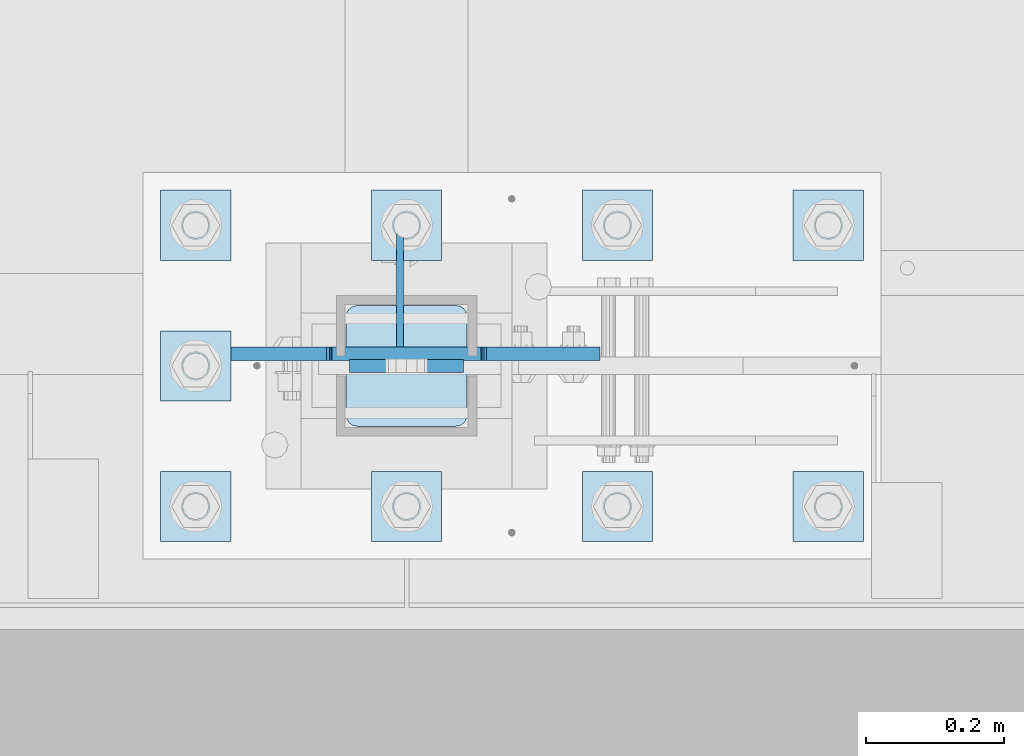
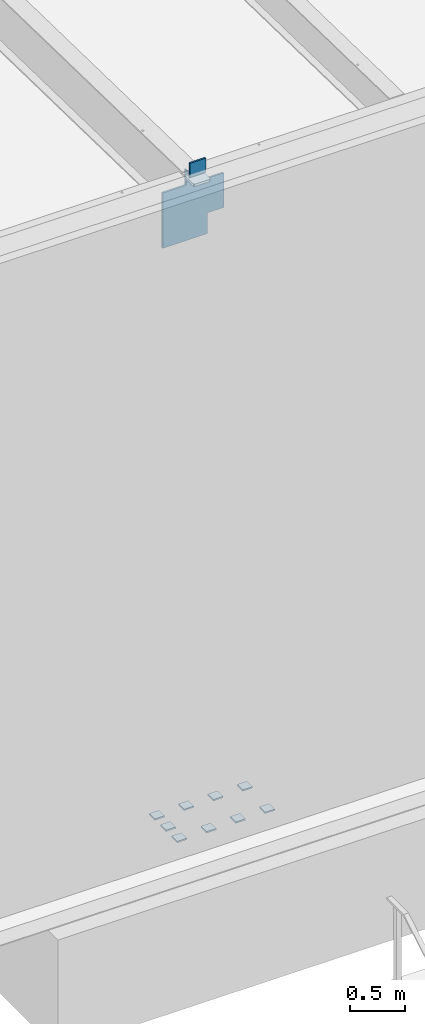
# One storey, part 1485 of 1763: 13 plates, 2 elements without a shape of their own.
"""IFC2X3 building model written with IfcOpenShell, lengths in millimetres."""

from ifc_helpers import new_model, si_unit, frame, origin_with_axes, place, context, subcontext, project, spatial, faceted_brep, material, type_object, element, aggregate, save


model = new_model("IFC2X3")

# Units and contexts
model_context = context("Model", 3, precision=1e-05, world=origin_with_axes())
body_context = subcontext(model_context, "Body", "Model", "MODEL_VIEW")
ifc_project = project(units=[si_unit("LENGTHUNIT", "METRE", prefix="MILLI"), si_unit("AREAUNIT", "SQUARE_METRE"), si_unit("VOLUMEUNIT", "CUBIC_METRE"), si_unit("MASSUNIT", "GRAM", prefix="KILO"), si_unit("TIMEUNIT", "SECOND"), si_unit("PLANEANGLEUNIT", "RADIAN"), si_unit("SOLIDANGLEUNIT", "STERADIAN"), si_unit("THERMODYNAMICTEMPERATUREUNIT", "DEGREE_CELSIUS"), si_unit("LUMINOUSINTENSITYUNIT", "LUMEN")], contexts=[model_context])

# Site, building, storey
site_placement = place(None, origin_with_axes())
site = spatial("IfcSite", under=ifc_project, at=site_placement, CompositionType="ELEMENT")
building_placement = place(site_placement, origin_with_axes())
building = spatial("IfcBuilding", under=site, at=building_placement, Name="Undefined", CompositionType="ELEMENT")
storey_placement = place(building_placement, origin_with_axes())
storey = spatial("IfcBuildingStorey", under=building, at=storey_placement, Name="Undefined", CompositionType="ELEMENT", Elevation=0.0)

# Assembly, plates
assembly_1_placement = place(storey_placement, origin_with_axes())
assembly_1 = element("IfcElementAssembly", 1, at=assembly_1_placement, inside=storey, Name="TEMPLATE", AssemblyPlace="NOTDEFINED", PredefinedType="RIGID_FRAME")
ifc_material_1 = material(Name="STEEL/A36")
plate_type_1 = type_object("IfcPlateType", PredefinedType="NOTDEFINED")
plate_1_placement = place(assembly_1_placement, frame((-35203.8372736984, -13868.4, 5138.7375), z_axis=(-1.0, 0.0, 0.0), x_axis=(0.0, -1.0, 0.0)))
plate_1 = element("IfcPlate", 2, at=plate_1_placement, type_object=plate_type_1, material=ifc_material_1, Name="WASHER PLATE", context=body_context, shape_type="Brep", body=[
    faceted_brep([(-7.27595761418343e-12, -7.9375, 0.0), (0.0, -7.9375, 101.599998474121), (0.0, 7.9375, 101.599998474121), (-7.27595761418343e-12, 7.9375, 0.0), (101.599998474121, -7.9375, 101.599998474121), (101.599998474121, 7.9375, 101.599998474121), (101.599998474121, -7.9375, 0.0), (101.599998474121, 7.9375, 0.0)], [[[0, 1, 2, 3]], [[1, 4, 5, 2]], [[4, 6, 7, 5]], [[6, 0, 3, 7]], [[5, 7, 3, 2]], [[6, 4, 1, 0]]]),
])
plate_2_placement = place(assembly_1_placement, frame((-34899.0372736983, -13868.4, 5138.7375), z_axis=(-1.0, 0.0, 0.0), x_axis=(0.0, -1.0, 0.0)))
plate_2 = element("IfcPlate", 3, at=plate_2_placement, type_object=plate_type_1, material=ifc_material_1, Name="WASHER PLATE", context=body_context, shape_type="Brep", body=[
    faceted_brep([(-7.27595761418343e-12, -7.9375, 0.0), (0.0, -7.9375, 101.599998474121), (0.0, 7.9375, 101.599998474121), (-7.27595761418343e-12, 7.9375, 0.0), (101.599998474121, -7.9375, 101.599998474121), (101.599998474121, 7.9375, 101.599998474121), (101.599998474121, -7.9375, 0.0), (101.599998474121, 7.9375, 0.0)], [[[0, 1, 2, 3]], [[1, 4, 5, 2]], [[4, 6, 7, 5]], [[6, 0, 3, 7]], [[5, 7, 3, 2]], [[6, 4, 1, 0]]]),
])
plate_3_placement = place(assembly_1_placement, frame((-34594.2372736983, -13868.4, 5138.7375), z_axis=(-1.0, 0.0, 0.0), x_axis=(0.0, -1.0, 0.0)))
plate_3 = element("IfcPlate", 4, at=plate_3_placement, type_object=plate_type_1, material=ifc_material_1, Name="WASHER PLATE", context=body_context, shape_type="Brep", body=[
    faceted_brep([(-7.27595761418343e-12, -7.9375, 0.0), (0.0, -7.9375, 101.599998474121), (0.0, 7.9375, 101.599998474121), (-7.27595761418343e-12, 7.9375, 0.0), (101.599998474121, -7.9375, 101.599998474121), (101.599998474121, 7.9375, 101.599998474121), (101.599998474121, -7.9375, 0.0), (101.599998474121, 7.9375, 0.0)], [[[0, 1, 2, 3]], [[1, 4, 5, 2]], [[4, 6, 7, 5]], [[6, 0, 3, 7]], [[5, 7, 3, 2]], [[6, 4, 1, 0]]]),
])
plate_4_placement = place(assembly_1_placement, frame((-34289.4372736983, -13868.4, 5138.7375), z_axis=(-1.0, 0.0, 0.0), x_axis=(0.0, -1.0, 0.0)))
plate_4 = element("IfcPlate", 5, at=plate_4_placement, type_object=plate_type_1, material=ifc_material_1, Name="WASHER PLATE", context=body_context, shape_type="Brep", body=[
    faceted_brep([(-7.27595761418343e-12, -7.9375, 0.0), (0.0, -7.9375, 101.599998474121), (0.0, 7.9375, 101.599998474121), (-7.27595761418343e-12, 7.9375, 0.0), (101.599998474121, -7.9375, 101.599998474121), (101.599998474121, 7.9375, 101.599998474121), (101.599998474121, -7.9375, 0.0), (101.599998474121, 7.9375, 0.0)], [[[0, 1, 2, 3]], [[1, 4, 5, 2]], [[4, 6, 7, 5]], [[6, 0, 3, 7]], [[5, 7, 3, 2]], [[6, 4, 1, 0]]]),
])
plate_5_placement = place(assembly_1_placement, frame((-35203.8372736984, -13665.2, 5138.7375), z_axis=(-1.0, 0.0, 0.0), x_axis=(0.0, -1.0, 0.0)))
plate_5 = element("IfcPlate", 6, at=plate_5_placement, type_object=plate_type_1, material=ifc_material_1, Name="WASHER PLATE", context=body_context, shape_type="Brep", body=[
    faceted_brep([(-7.27595761418343e-12, -7.9375, 0.0), (0.0, -7.9375, 101.599998474121), (0.0, 7.9375, 101.599998474121), (-7.27595761418343e-12, 7.9375, 0.0), (101.599998474121, -7.9375, 101.599998474121), (101.599998474121, 7.9375, 101.599998474121), (101.599998474121, -7.9375, 0.0), (101.599998474121, 7.9375, 0.0)], [[[0, 1, 2, 3]], [[1, 4, 5, 2]], [[4, 6, 7, 5]], [[6, 0, 3, 7]], [[5, 7, 3, 2]], [[6, 4, 1, 0]]]),
])
plate_6_placement = place(assembly_1_placement, frame((-35203.8372736984, -13462.0, 5138.7375), z_axis=(-1.0, 0.0, 0.0), x_axis=(0.0, -1.0, 0.0)))
plate_6 = element("IfcPlate", 7, at=plate_6_placement, type_object=plate_type_1, material=ifc_material_1, Name="WASHER PLATE", context=body_context, shape_type="Brep", body=[
    faceted_brep([(-7.27595761418343e-12, -7.9375, 0.0), (0.0, -7.9375, 101.599998474121), (0.0, 7.9375, 101.599998474121), (-7.27595761418343e-12, 7.9375, 0.0), (101.599998474121, -7.9375, 101.599998474121), (101.599998474121, 7.9375, 101.599998474121), (101.599998474121, -7.9375, 0.0), (101.599998474121, 7.9375, 0.0)], [[[0, 1, 2, 3]], [[1, 4, 5, 2]], [[4, 6, 7, 5]], [[6, 0, 3, 7]], [[5, 7, 3, 2]], [[6, 4, 1, 0]]]),
])
plate_7_placement = place(assembly_1_placement, frame((-34899.0372736983, -13462.0, 5138.7375), z_axis=(-1.0, 0.0, 0.0), x_axis=(0.0, -1.0, 0.0)))
plate_7 = element("IfcPlate", 8, at=plate_7_placement, type_object=plate_type_1, material=ifc_material_1, Name="WASHER PLATE", context=body_context, shape_type="Brep", body=[
    faceted_brep([(-7.27595761418343e-12, -7.9375, 0.0), (0.0, -7.9375, 101.599998474121), (0.0, 7.9375, 101.599998474121), (-7.27595761418343e-12, 7.9375, 0.0), (101.599998474121, -7.9375, 101.599998474121), (101.599998474121, 7.9375, 101.599998474121), (101.599998474121, -7.9375, 0.0), (101.599998474121, 7.9375, 0.0)], [[[0, 1, 2, 3]], [[1, 4, 5, 2]], [[4, 6, 7, 5]], [[6, 0, 3, 7]], [[5, 7, 3, 2]], [[6, 4, 1, 0]]]),
])
plate_8_placement = place(assembly_1_placement, frame((-34594.2372736983, -13462.0, 5138.7375), z_axis=(-1.0, 0.0, 0.0), x_axis=(0.0, -1.0, 0.0)))
plate_8 = element("IfcPlate", 9, at=plate_8_placement, type_object=plate_type_1, material=ifc_material_1, Name="WASHER PLATE", context=body_context, shape_type="Brep", body=[
    faceted_brep([(-7.27595761418343e-12, -7.9375, 0.0), (0.0, -7.9375, 101.599998474121), (0.0, 7.9375, 101.599998474121), (-7.27595761418343e-12, 7.9375, 0.0), (101.599998474121, -7.9375, 101.599998474121), (101.599998474121, 7.9375, 101.599998474121), (101.599998474121, -7.9375, 0.0), (101.599998474121, 7.9375, 0.0)], [[[0, 1, 2, 3]], [[1, 4, 5, 2]], [[4, 6, 7, 5]], [[6, 0, 3, 7]], [[5, 7, 3, 2]], [[6, 4, 1, 0]]]),
])
plate_9_placement = place(assembly_1_placement, frame((-34289.4372736983, -13462.0, 5138.7375), z_axis=(-1.0, 0.0, 0.0), x_axis=(0.0, -1.0, 0.0)))
plate_9 = element("IfcPlate", 10, at=plate_9_placement, type_object=plate_type_1, material=ifc_material_1, Name="WASHER PLATE", context=body_context, shape_type="Brep", body=[
    faceted_brep([(-7.27595761418343e-12, -7.9375, 0.0), (0.0, -7.9375, 101.599998474121), (0.0, 7.9375, 101.599998474121), (-7.27595761418343e-12, 7.9375, 0.0), (101.599998474121, -7.9375, 101.599998474121), (101.599998474121, 7.9375, 101.599998474121), (101.599998474121, -7.9375, 0.0), (101.599998474121, 7.9375, 0.0)], [[[0, 1, 2, 3]], [[1, 4, 5, 2]], [[4, 6, 7, 5]], [[6, 0, 3, 7]], [[5, 7, 3, 2]], [[6, 4, 1, 0]]]),
])
aggregate(assembly_1, [plate_1, plate_2, plate_3, plate_4, plate_5, plate_6, plate_7, plate_8, plate_9])

assembly_2_placement = place(storey_placement, origin_with_axes())
assembly_2 = element("IfcElementAssembly", 11, at=assembly_2_placement, inside=storey, Name="COLUMN", AssemblyPlace="NOTDEFINED", PredefinedType="RIGID_FRAME")
ifc_material_2 = material(Name="STEEL/A572-50")
plate_type_2 = type_object("IfcPlateType", PredefinedType="NOTDEFINED")
plate_10_placement = place(assembly_2_placement, frame((-34867.2872721725, -13715.9998186171, 12369.7999938965), z_axis=(0.0, 0.0, -1.0), x_axis=(-1.0, 0.0, 0.0)))
plate_10 = element("IfcPlate", 12, at=plate_10_placement, type_object=plate_type_2, material=ifc_material_2, Name="PLATE", context=body_context, shape_type="Brep", body=[
    faceted_brep([(7.27595761418343e-12, 9.52500000000146, 155.574990844727), (-1.45519152283669e-11, 7.27595761418343e-12, 165.099990844727), (165.099990844727, 0.0, 165.099990844727), (165.099990844727, 9.52500000000146, 155.574990844727), (-3.63797880709171e-11, -9.5249999999869, 155.574990844727), (165.099990844727, -9.52500000000146, 155.574990844727), (0.0, 9.52500000000146, 0.0), (0.0, -9.52500000000146, 0.0), (165.099990844727, -9.52500000000146, 0.0), (165.099990844727, 9.52500000000146, 0.0)], [[[0, 1, 2, 3]], [[1, 4, 5, 2]], [[6, 7, 4, 1, 0]], [[5, 8, 9, 3, 2]], [[8, 7, 6, 9]], [[9, 6, 0, 3]], [[7, 8, 5, 4]]]),
])
plate_type_3 = type_object("IfcPlateType", PredefinedType="NOTDEFINED")
plate_11_placement = place(assembly_2_placement, frame((-35057.7872736983, -13698.5378187239, 12128.5), z_axis=(1.0, 0.0, 0.0), x_axis=(0.0, 0.0, 1.0)))
plate_11 = element("IfcPlate", 13, at=plate_11_placement, type_object=plate_type_3, material=ifc_material_2, Name="PLATE", context=body_context, shape_type="Brep", body=[
    faceted_brep([(1.54303415911272e-06, -9.52499999999964, 387.350006103516), (1.14298018161207e-07, -9.52499999999964, 228.599993819233), (1.14298018161207e-07, 9.52499999999964, 228.599993819233), (1.54303415911272e-06, 9.52499999999964, 387.350006103516), (0.966730004003693, -9.52499999999964, 223.739914266276), (0.966730004003693, 9.52499999999964, 223.739914266276), (3.71974389666684, -9.52499999999964, 219.619737759436), (3.71974389666684, 9.52499999999964, 219.619737759436), (7.83992037855387, -9.52499999999964, 216.866723829429), (7.83992037855387, 9.52499999999964, 216.866723829429), (12.6999999227501, -9.52499999999964, 215.899993895669), (12.6999999227501, 9.52499999999964, 215.899993895669), (31.75, -9.52499999999964, 215.899993894447), (31.75, 9.52499999999964, 215.899993894447), (-381.0, -9.52499999999964, 228.59999370575), (-381.0, -9.52499999999964, 387.350006103516), (-381.0, 9.52499999999964, 387.350006103516), (-381.0, 9.52499999999964, 228.59999370575), (-381.966729922588, -9.52499999999964, 223.739914187703), (-381.966729922588, 9.52499999999964, 223.739914187703), (-384.719743823065, -9.52499999999964, 219.619737719549), (-384.719743823065, 9.52499999999964, 219.619737719549), (-388.839920291219, -9.52499999999964, 216.866723819076), (-388.839920291219, 9.52499999999964, 216.866723819076), (-393.699999809265, -9.52499999999964, 215.899993896484), (-393.699999809265, 9.52499999999964, 215.899993896484), (-609.599975585938, -9.52499999999964, 215.899993896484), (-609.599975585938, 9.52499999999964, 215.899993896484), (-609.599975585938, -9.52499999999964, -247.649993896484), (-609.599975585938, 9.52499999999964, -247.649993896484), (0.0, -9.52499999999964, -247.649993896484), (0.0, 9.52499999999964, -247.649993896484), (0.0, -9.52499999999964, -12.6999998092651), (3.19665128194256e-12, 9.52499999999854, -12.699999332428), (0.966729922587547, -9.52499999999964, -7.83992029122601), (0.966729922587547, 9.52499999999964, -7.83992029122601), (3.71974382306507, -9.52499999999964, -3.71974382306507), (3.71974382306507, 9.52499999999964, -3.71974382306507), (7.83992029121873, -9.52499999999964, -0.966729922583909), (7.83992029121873, 9.52499999999964, -0.966729922583909), (12.6999998092651, -9.52499999999964, 0.0), (12.6999998092651, 9.52499999999964, 0.0), (31.7500000000055, 9.52499999999964, 0.0), (31.7500000000055, -9.52499999999964, 0.0)], [[[0, 1, 2, 3]], [[4, 5, 2, 1]], [[6, 7, 5, 4]], [[8, 9, 7, 6]], [[10, 11, 9, 8]], [[12, 13, 11, 10]], [[14, 15, 16, 17]], [[18, 14, 17, 19]], [[20, 18, 19, 21]], [[22, 20, 21, 23]], [[24, 22, 23, 25]], [[26, 24, 25, 27]], [[28, 26, 27, 29]], [[30, 28, 29, 31]], [[32, 30, 31, 33]], [[34, 32, 33, 35]], [[36, 34, 35, 37]], [[38, 36, 37, 39]], [[40, 38, 39, 41]], [[40, 41, 42, 43]], [[8, 6, 4, 1, 0, 15, 14, 18, 20, 22, 24, 26, 28, 30, 32, 34, 36, 38, 40, 43, 12, 10]], [[16, 15, 0, 3]], [[42, 41, 39, 37, 35, 33, 31, 29, 27, 25, 23, 21, 19, 17, 16, 3, 2, 5, 7, 9, 11, 13]], [[43, 42, 13, 12]]]),
])
plate_type_4 = type_object("IfcPlateType", PredefinedType="NOTDEFINED")
plate_12_placement = place(assembly_2_placement, frame((-34862.5247736984, -13628.6875, 12172.95), z_axis=(0.0, -1.0, 0.0), x_axis=(-1.0, 0.0, 0.0)))
plate_12 = element("IfcPlate", 14, at=plate_12_placement, type_object=plate_type_4, material=ifc_material_1, Name="PLATE", context=body_context, shape_type="Brep", body=[
    faceted_brep([(-2.18278728425503e-11, -12.7000000000007, 15.875), (0.0, -12.7000000000007, 158.75), (0.0, 12.7000000000007, 158.75), (-2.18278728425503e-11, 12.7000000000007, 15.875), (1.20841242138704, -12.7000000000007, 164.825099488797), (1.20841242138704, 12.7000000000007, 164.825099488797), (4.6496798486769, -12.7000000000007, 169.975320151338), (4.6496798486769, 12.7000000000007, 169.975320151338), (9.79990051120694, -12.7000000000007, 173.416587578617), (9.79990051120694, 12.7000000000007, 173.416587578617), (15.875, -12.7000000000007, 174.625), (15.875, 12.7000000000007, 174.625), (158.75, -12.7000000000007, 174.625), (158.75, 12.7000000000007, 174.625), (164.825099488793, -12.7000000000007, 173.416587578617), (164.825099488793, 12.7000000000007, 173.416587578617), (169.975320151338, -12.7000000000007, 169.975320151336), (169.975320151338, 12.7000000000007, 169.975320151336), (173.416587578613, -12.7000000000007, 164.825099488797), (173.416587578613, 12.7000000000007, 164.825099488797), (174.625, -12.7000000000007, 158.75), (174.625, 12.7000000000007, 158.75), (174.625, -12.7000000000007, 15.8750000000073), (174.625, 12.7000000000007, 15.8750000000073), (173.416587578613, -12.7000000000007, 9.79990051121058), (173.416587578613, 12.7000000000007, 9.79990051121058), (169.975320151338, -12.7000000000007, 4.64967984866962), (169.975320151338, 12.7000000000007, 4.64967984866962), (164.825099488793, -12.7000000000007, 1.20841242139068), (164.825099488793, 12.7000000000007, 1.20841242139068), (158.75, -12.7000000000007, 7.27595761418343e-12), (158.75, 12.7000000000007, 7.27595761418343e-12), (15.8749999999854, -12.7000000000007, 0.0), (15.8749999999854, 12.7000000000007, 0.0), (9.79990051119239, -12.7000000000007, 1.20841242137976), (9.79990051119239, 12.7000000000007, 1.20841242137976), (4.64967984864779, -12.7000000000007, 4.64967984866234), (4.64967984864779, 12.7000000000007, 4.64967984866234), (1.20841242136521, -12.7000000000007, 9.79990051119967), (1.20841242136521, 12.7000000000007, 9.79990051119967)], [[[0, 1, 2, 3]], [[1, 4, 5, 2]], [[4, 6, 7, 5]], [[6, 8, 9, 7]], [[8, 10, 11, 9]], [[10, 12, 13, 11]], [[12, 14, 15, 13]], [[14, 16, 17, 15]], [[16, 18, 19, 17]], [[18, 20, 21, 19]], [[20, 22, 23, 21]], [[22, 24, 25, 23]], [[24, 26, 27, 25]], [[26, 28, 29, 27]], [[28, 30, 31, 29]], [[30, 32, 33, 31]], [[32, 34, 35, 33]], [[34, 36, 37, 35]], [[36, 38, 39, 37]], [[38, 0, 3, 39]], [[5, 7, 9, 11, 13, 15, 17, 19, 21, 23, 25, 27, 29, 31, 33, 35, 37, 39, 3, 2]], [[38, 36, 34, 32, 30, 28, 26, 24, 22, 20, 18, 16, 14, 12, 10, 8, 6, 4, 1, 0]]]),
])
plate_type_5 = type_object("IfcPlateType", PredefinedType="NOTDEFINED")
plate_13_placement = place(assembly_2_placement, frame((-34959.3622729411, -13614.4, 12160.2416542355), z_axis=(0.0, 0.0, -1.0), x_axis=(0.0, -1.0, 0.0)))
plate_13 = element("IfcPlate", 15, at=plate_13_placement, type_object=plate_type_5, material=ifc_material_1, Name="PLATE", context=body_context, shape_type="Brep", body=[
    faceted_brep([(0.0, -4.76249999999982, 0.0), (-101.599998474121, -4.76249999999709, 0.0), (-101.599998474121, 4.76249999999709, 0.0), (0.0, 4.76249999999982, 0.0), (-101.599998474121, -4.76249999999709, 542.131225585938), (-101.599998474121, 4.76249999999709, 542.131225585938), (74.6125030517578, -4.76249999999709, 542.131225585938), (74.6125030517578, 4.76249999999709, 542.131225585938), (74.6125030517578, -4.76249999999999, 0.0), (74.6125030517578, 4.76249999999999, 0.0)], [[[0, 1, 2, 3]], [[1, 4, 5, 2]], [[4, 6, 7, 5]], [[6, 8, 9, 7]], [[8, 0, 3, 9]], [[5, 7, 9, 3, 2]], [[8, 6, 4, 1, 0]]]),
])
aggregate(assembly_2, [plate_11, plate_12, plate_10, plate_13])

save(model, "model.ifc")
